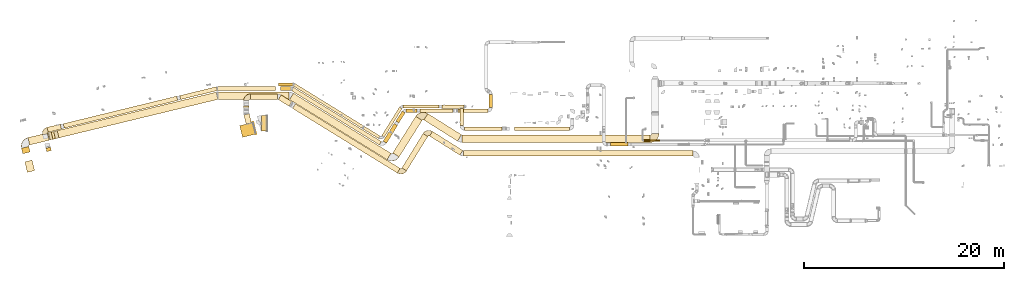
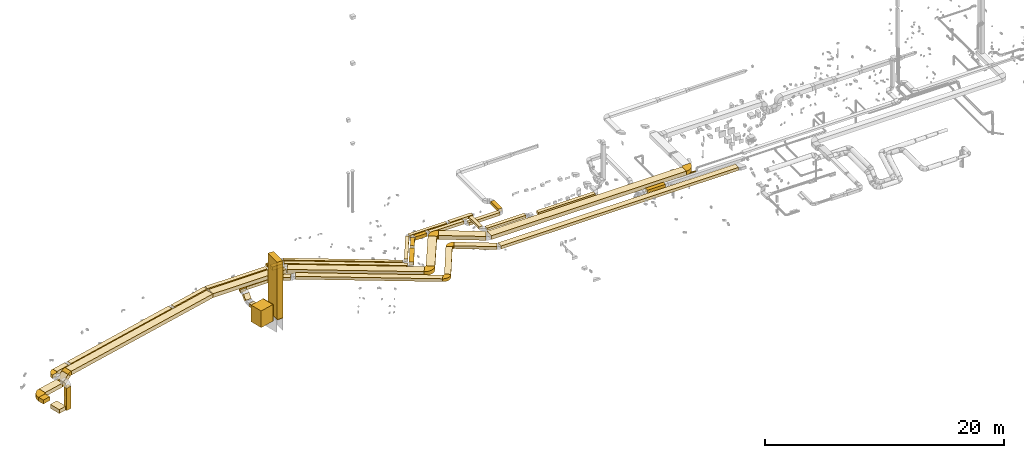
# One storey, part 1 of 97: 55 coverings.
"""IFC2X3 building model written with IfcOpenShell, lengths in millimetres."""

from ifc_helpers import new_model, entity, si_unit, converted_unit, derived_unit, direction, frame, frame_2d, origin, origin_2d_with_axis, place, context, subcontext, project, spatial, polyline, circle_curve, parameter, trimmed, segment, composite_curve, rectangle, circle, outline, extrude, element, save


model = new_model("IFC2X3")

# Units and contexts
model_context = context("Model", 3, precision=0.01, world=origin(), true_north=direction((6.12303176911189e-17, 1.0)))
body_context = subcontext(model_context, "Body", "Model", "MODEL_VIEW")
ifc_project = project(units=[si_unit("LENGTHUNIT", "METRE", prefix="MILLI"), si_unit("AREAUNIT", "SQUARE_METRE"), si_unit("VOLUMEUNIT", "CUBIC_METRE"), converted_unit("PLANEANGLEUNIT", "DEGREE", entity("IfcRatioMeasure", 0.0174532925199433), si_unit("PLANEANGLEUNIT", "RADIAN"), dimensions=[0, 0, 0, 0, 0, 0, 0]), si_unit("MASSUNIT", "GRAM", prefix="KILO"), derived_unit("MASSDENSITYUNIT", [(si_unit("MASSUNIT", "GRAM", prefix="KILO"), 1), (si_unit("LENGTHUNIT", "METRE"), -3)]), derived_unit("MOMENTOFINERTIAUNIT", [(si_unit("LENGTHUNIT", "METRE"), 4)]), si_unit("TIMEUNIT", "SECOND"), si_unit("FREQUENCYUNIT", "HERTZ"), si_unit("THERMODYNAMICTEMPERATUREUNIT", "DEGREE_CELSIUS"), derived_unit("THERMALTRANSMITTANCEUNIT", [(si_unit("MASSUNIT", "GRAM", prefix="KILO"), 1), (si_unit("THERMODYNAMICTEMPERATUREUNIT", "KELVIN"), -1), (si_unit("TIMEUNIT", "SECOND"), -3)]), derived_unit("VOLUMETRICFLOWRATEUNIT", [(si_unit("LENGTHUNIT", "METRE"), 3), (si_unit("TIMEUNIT", "SECOND"), -1)]), derived_unit("MASSFLOWRATEUNIT", [(si_unit("MASSUNIT", "GRAM", prefix="KILO"), 1), (si_unit("TIMEUNIT", "SECOND"), -1)]), derived_unit("ROTATIONALFREQUENCYUNIT", [(si_unit("TIMEUNIT", "SECOND"), -1)]), si_unit("ELECTRICCURRENTUNIT", "AMPERE"), si_unit("ELECTRICVOLTAGEUNIT", "VOLT"), si_unit("POWERUNIT", "WATT"), si_unit("FORCEUNIT", "NEWTON", prefix="KILO"), si_unit("ILLUMINANCEUNIT", "LUX"), si_unit("LUMINOUSFLUXUNIT", "LUMEN"), si_unit("LUMINOUSINTENSITYUNIT", "CANDELA"), derived_unit("USERDEFINED", [(si_unit("MASSUNIT", "GRAM", prefix="KILO"), -1), (si_unit("LENGTHUNIT", "METRE"), -2), (si_unit("TIMEUNIT", "SECOND"), 3), (si_unit("LUMINOUSFLUXUNIT", "LUMEN"), 1)]), derived_unit("LINEARVELOCITYUNIT", [(si_unit("LENGTHUNIT", "METRE"), 1), (si_unit("TIMEUNIT", "SECOND"), -1)]), si_unit("PRESSUREUNIT", "PASCAL"), derived_unit("USERDEFINED", [(si_unit("LENGTHUNIT", "METRE"), -2), (si_unit("MASSUNIT", "GRAM", prefix="KILO"), 1), (si_unit("TIMEUNIT", "SECOND"), -2)]), derived_unit("LINEARFORCEUNIT", [(si_unit("MASSUNIT", "GRAM", prefix="KILO"), 1), (si_unit("LENGTHUNIT", "METRE"), 1), (si_unit("TIMEUNIT", "SECOND"), -2), (si_unit("LENGTHUNIT", "METRE"), -1)]), derived_unit("PLANARFORCEUNIT", [(si_unit("MASSUNIT", "GRAM", prefix="KILO"), 1), (si_unit("LENGTHUNIT", "METRE"), 1), (si_unit("TIMEUNIT", "SECOND"), -2), (si_unit("LENGTHUNIT", "METRE"), -2)])], contexts=[model_context])

# Site, building, storey
site_placement = place(None, origin())
site = spatial("IfcSite", under=ifc_project, at=site_placement, CompositionType="ELEMENT")
building_placement = place(site_placement, origin())
building = spatial("IfcBuilding", under=site, at=building_placement, CompositionType="ELEMENT")
storey_placement = place(building_placement, frame((0.0, 0.0, -4900.0)))
storey = spatial("IfcBuildingStorey", under=building, at=storey_placement, CompositionType="ELEMENT", Elevation=-4900.0)

# Coverings
covering_1_placement = place(storey_placement, frame((-3208.67, 9959.38, 2456.63)))
element("IfcCovering", 1, at=covering_1_placement, inside=storey, PredefinedType="INSULATION", context=body_context, shape_type="SweptSolid", body=[
    extrude(rectangle(XDim=1360.0, YDim=1200.0, at=origin_2d_with_axis()), frame((803.51, 744.9, 0.0), z_axis=(0.0, 0.0, 1.0), x_axis=(-0.971126038182249, -0.238567009379859, 0.0)), (0.0, 0.0, 1.0), 1700.0),
])
covering_2_placement = place(storey_placement, frame((-1887.94, 10283.83, 2456.63)))
element("IfcCovering", 2, at=covering_2_placement, inside=storey, PredefinedType="INSULATION", context=body_context, shape_type="SweptSolid", body=[
    extrude(rectangle(XDim=50.0000000000032, YDim=1200.0, at=origin_2d_with_axis()), frame((167.42, 588.64, 0.0), z_axis=(0.0, 0.0, 1.0), x_axis=(-0.971126038182248, -0.238567009379862, 0.0)), (0.0, 0.0, 1.0), 1700.0),
])
covering_3_placement = place(storey_placement, frame((-2794.72, 11277.28, 3200.0)))
element("IfcCovering", 3, at=covering_3_placement, inside=storey, PredefinedType="INSULATION", context=body_context, shape_type="SweptSolid", body=[
    extrude(rectangle(XDim=955.574923264787, YDim=550.0, at=origin_2d_with_axis()), frame((381.04, 529.6, 0.0), z_axis=(0.0, 0.0, 1.0), x_axis=(-0.238567009379864, 0.971126038182248, 0.0)), (0.0, 0.0, 1.0), 300.0),
])
covering_4_placement = place(storey_placement, frame((-2814.21, 12716.67, 3324.48)))
element("IfcCovering", 4, at=covering_4_placement, inside=storey, PredefinedType="INSULATION", context=body_context, shape_type="SweptSolid", body=[
    extrude(rectangle(XDim=549.999806950779, YDim=299.999999999998, at=origin_2d_with_axis()), frame((0.0, 300.52, 300.52), z_axis=(1.0, 0.0, 0.0), x_axis=(0.0, 0.707106781186531, 0.707106781186564)), (0.0, 0.0, 1.0), 550.0),
])
covering_5_placement = place(storey_placement, frame((-2139.22, 13746.58, 3750.0)))
element("IfcCovering", 5, at=covering_5_placement, inside=storey, PredefinedType="INSULATION", context=body_context, shape_type="SweptSolid", body=[
    extrude(rectangle(XDim=2716.99429169592, YDim=550.000000000001, at=origin_2d_with_axis()), frame((1358.5, 275.0, 0.01), z_axis=(-6.17522343880966e-06, 0.0, 1.0), x_axis=(-1.0, 0.0, -6.17522343880966e-06)), (0.0, 0.0, 1.0), 300.0),
])
covering_6_placement = place(storey_placement, frame((643.41, 13064.74, 3750.02)))
element("IfcCovering", 6, at=covering_6_placement, inside=storey, PredefinedType="INSULATION", context=body_context, shape_type="SweptSolid", body=[
    extrude(rectangle(XDim=1263.23389062577, YDim=550.0, at=origin_2d_with_axis()), frame((681.94, 565.66, 0.0), z_axis=(-2.60900913908676e-07, 1.60945190401383e-07, 1.0), x_axis=(0.851088816343154, -0.525021739259923, 3.0654957379145e-07)), (0.0, 0.0, 1.0), 300.0),
])
covering_7_placement = place(storey_placement, frame((15756.5, 8178.55, 3900.0)))
element("IfcCovering", 7, at=covering_7_placement, inside=storey, PredefinedType="INSULATION", context=body_context, shape_type="SweptSolid", body=[
    extrude(rectangle(XDim=3583.77962437014, YDim=550.0, at=origin_2d_with_axis()), frame((1663.15, 1186.95, 0.0), z_axis=(0.0, 0.0, 1.0), x_axis=(-0.846428930081417, 0.532501705463211, 0.0)), (0.0, 0.0, 1.0), 300.0),
])
covering_8_placement = place(storey_placement, frame((19149.36, 8074.88, 3900.0)))
element("IfcCovering", 8, at=covering_8_placement, inside=storey, PredefinedType="INSULATION", context=body_context, shape_type="SweptSolid", body=[
    extrude(rectangle(XDim=22913.242395076, YDim=550.000000000001, at=origin_2d_with_axis()), frame((11456.62, 275.0, 0.0)), (0.0, 0.0, 1.0), 300.0),
])
covering_9_placement = place(storey_placement, frame((18780.54, 11120.0, 4175.0)))
element("IfcCovering", 9, at=covering_9_placement, inside=storey, PredefinedType="INSULATION", context=body_context, shape_type="SweptSolid", body=[
    extrude(rectangle(XDim=1744.07623364408, YDim=349.999999999998, at=origin_2d_with_axis()), frame((175.0, 872.04, 0.0), z_axis=(0.0, -1.06842108780278e-08, 1.0), x_axis=(0.0, -1.0, -1.06842108780278e-08)), (0.0, 0.0, 1.0), 250.0),
])
covering_10_placement = place(storey_placement, frame((24231.5, 10645.0, 4025.0)))
element("IfcCovering", 10, at=covering_10_placement, inside=storey, PredefinedType="INSULATION", context=body_context, shape_type="SweptSolid", body=[
    extrude(rectangle(XDim=5495.94816144537, YDim=349.999999999998, at=origin_2d_with_axis()), frame((2747.97, 175.0, 0.0), z_axis=(0.0, 0.0, 1.0), x_axis=(-1.0, 0.0, 0.0)), (0.0, 0.0, 1.0), 250.0),
])
covering_11_placement = place(storey_placement, frame((2157.8, 9839.85, 4225.0)))
element("IfcCovering", 11, at=covering_11_placement, inside=storey, PredefinedType="INSULATION", context=body_context, shape_type="SweptSolid", body=[
    extrude(rectangle(XDim=9982.84701585936, YDim=299.999999999999, at=origin_2d_with_axis()), frame((4326.9, 2748.27, 0.0), z_axis=(0.0, 0.0, 1.0), x_axis=(-0.851088806352979, 0.525021755454629, 0.0)), (0.0, 0.0, 1.0), 250.0),
])
covering_12_placement = place(storey_placement, frame((10983.34, 9976.93, 4225.0)))
element("IfcCovering", 12, at=covering_12_placement, inside=storey, PredefinedType="INSULATION", context=body_context, shape_type="SweptSolid", body=[
    extrude(rectangle(XDim=3355.15981218457, YDim=300.0, at=origin_2d_with_axis()), frame((1014.01, 1503.39, 0.0), z_axis=(0.0, 0.0, 1.0), x_axis=(0.528543816030324, 0.84890602220511, 0.0)), (0.0, 0.0, 1.0), 250.0),
])
covering_13_placement = place(storey_placement, frame((13117.47, 12884.08, 4225.0)))
element("IfcCovering", 13, at=covering_13_placement, inside=storey, PredefinedType="INSULATION", context=body_context, shape_type="SweptSolid", body=[
    extrude(rectangle(XDim=3578.96571761756, YDim=300.000000000001, at=origin_2d_with_axis()), frame((1789.48, 150.0, 0.0)), (0.0, 0.0, 1.0), 250.0),
])
covering_14_placement = place(storey_placement, frame((16996.44, 12859.08, 4225.0)))
element("IfcCovering", 14, at=covering_14_placement, inside=storey, PredefinedType="INSULATION", context=body_context, shape_type="SweptSolid", body=[
    extrude(rectangle(XDim=2209.11071214288, YDim=349.999999999998, at=origin_2d_with_axis()), frame((1104.56, 175.0, 0.0)), (0.0, 0.0, 1.0), 250.0),
])
covering_15_placement = place(storey_placement, frame((-24682.89, 6452.66, 3350.0)))
element("IfcCovering", 15, at=covering_15_placement, inside=storey, PredefinedType="INSULATION", context=body_context, shape_type="SweptSolid", body=[
    extrude(rectangle(XDim=1079.40182496234, YDim=749.999999999998, at=origin_2d_with_axis()), frame((493.23, 613.74, 0.0), z_axis=(0.0, 0.0, 1.0), x_axis=(-0.239234929345687, 0.970961713241549, 0.0)), (0.0, 0.0, 1.0), 400.0),
])
covering_16_placement = place(storey_placement, frame((-25019.06, 8317.78, 3350.0)))
element("IfcCovering", 16, at=covering_16_placement, inside=storey, PredefinedType="INSULATION", context=body_context, shape_type="SweptSolid", body=[
    extrude(rectangle(XDim=563.648083324207, YDim=749.999999999999, at=origin_2d_with_axis()), frame((431.53, 363.36, 0.0), z_axis=(0.0, 0.0, 1.0), x_axis=(-0.239240175396018, 0.970960420653943, 0.0)), (0.0, 0.0, 1.0), 400.0),
])
covering_17_placement = place(storey_placement, frame((-24375.2, 9195.88, 3350.0)))
element("IfcCovering", 17, at=covering_17_placement, inside=storey, PredefinedType="INSULATION", context=body_context, shape_type="SweptSolid", body=[
    extrude(rectangle(XDim=2019.81232553969, YDim=750.0, at=origin_2d_with_axis()), frame((1069.77, 601.95, 0.0), z_axis=(0.0, 0.0, 1.0), x_axis=(0.971963923974013, 0.235130028905367, 0.0)), (0.0, 0.0, 1.0), 400.0),
])
covering_18_placement = place(storey_placement, frame((-5356.59, 13750.46, 4075.0)))
element("IfcCovering", 18, at=covering_18_placement, inside=storey, PredefinedType="INSULATION", context=body_context, shape_type="SweptSolid", body=[
    extrude(rectangle(XDim=7058.84355228445, YDim=749.999999999998, at=origin_2d_with_axis()), frame((3529.42, 375.0, 0.0), z_axis=(0.0, 0.0, 1.0), x_axis=(-1.0, 0.0, 0.0)), (0.0, 0.0, 1.0), 400.0),
])
covering_19_placement = place(storey_placement, frame((1767.89, 7718.09, 4075.0)))
element("IfcCovering", 19, at=covering_19_placement, inside=storey, PredefinedType="INSULATION", context=body_context, shape_type="SweptSolid", body=[
    extrude(rectangle(XDim=11454.2887651558, YDim=750.0, at=origin_2d_with_axis()), frame((5071.19, 3326.03, 0.0), z_axis=(0.0, 0.0, 1.0), x_axis=(-0.851088797264639, 0.525021770187323, 0.0)), (0.0, 0.0, 1.0), 400.0),
])
covering_20_placement = place(storey_placement, frame((15190.71, 9579.38, 4075.0)))
element("IfcCovering", 20, at=covering_20_placement, inside=storey, PredefinedType="INSULATION", context=body_context, shape_type="SweptSolid", body=[
    extrude(rectangle(XDim=3972.83667806784, YDim=750.000000000002, at=origin_2d_with_axis()), frame((1881.05, 1375.18, 0.0), z_axis=(0.0, 0.0, 1.0), x_axis=(-0.84642893008142, 0.532501705463206, 0.0)), (0.0, 0.0, 1.0), 400.0),
])
covering_21_placement = place(storey_placement, frame((19019.38, 9445.01, 4075.0)))
element("IfcCovering", 21, at=covering_21_placement, inside=storey, PredefinedType="INSULATION", context=body_context, shape_type="SweptSolid", body=[
    extrude(rectangle(XDim=18790.1284833971, YDim=750.0, at=origin_2d_with_axis()), frame((9395.06, 375.0, 0.0)), (0.0, 0.0, 1.0), 400.0),
])
covering_22_placement = place(storey_placement, frame((12081.7, 7996.85, 4075.0)))
element("IfcCovering", 22, at=covering_22_placement, inside=storey, PredefinedType="INSULATION", context=body_context, shape_type="SweptSolid", body=[
    extrude(rectangle(XDim=4322.66331644128, YDim=749.999999999999, at=origin_2d_with_axis()), frame((1468.32, 2029.1, 0.0), z_axis=(0.0, 0.0, 1.0), x_axis=(0.532501705463199, 0.846428930081424, 0.0)), (0.0, 0.0, 1.0), 400.0),
])
covering_23_placement = place(storey_placement, frame((-22596.61, 8522.08, 1715.0)))
element("IfcCovering", 23, at=covering_23_placement, inside=storey, PredefinedType="INSULATION", context=body_context, shape_type="SweptSolid", body=[
    extrude(rectangle(XDim=350.0, YDim=499.999999999999, at=origin_2d_with_axis()), frame((284.28, 229.14, 0.0), z_axis=(1.3083476965024e-06, -5.37909916616792e-06, 1.0), x_axis=(0.236337623155927, -0.971670997740676, -5.53592643867416e-06)), (0.0, 0.0, 1.0), 2284.95162721462),
])
covering_24_placement = place(storey_placement, frame((-20841.09, 10877.98, 4125.0)))
element("IfcCovering", 24, at=covering_24_placement, inside=storey, PredefinedType="INSULATION", context=body_context, shape_type="SweptSolid", body=[
    extrude(rectangle(XDim=11666.6777760886, YDim=449.999999999998, at=origin_2d_with_axis()), frame((5720.72, 1599.9, 0.0), z_axis=(0.0, 0.0, 1.0), x_axis=(0.971559912665503, 0.236793868377963, 0.0)), (0.0, 0.0, 1.0), 350.0),
])
covering_25_placement = place(storey_placement, frame((-9208.82, 13735.91, 4125.0)))
element("IfcCovering", 25, at=covering_25_placement, inside=storey, PredefinedType="INSULATION", context=body_context, shape_type="SweptSolid", body=[
    extrude(rectangle(XDim=3774.44741521228, YDim=400.000000000001, at=origin_2d_with_axis()), frame((1880.91, 641.19, 0.0), z_axis=(0.0, 0.0, 1.0), x_axis=(0.9715599126655, 0.236793868377977, 0.0)), (0.0, 0.0, 1.0), 350.0),
])
covering_26_placement = place(storey_placement, frame((866.6, 14633.23, 4125.0)))
element("IfcCovering", 26, at=covering_26_placement, inside=storey, PredefinedType="INSULATION", context=body_context, shape_type="SweptSolid", body=[
    extrude(rectangle(XDim=1032.75527236275, YDim=400.0, at=origin_2d_with_axis()), frame((516.38, 200.0, 0.0), z_axis=(0.0, 0.0, 1.0), x_axis=(-1.0, 0.0, 0.0)), (0.0, 0.0, 1.0), 350.0),
])
covering_27_placement = place(storey_placement, frame((1964.98, 9200.43, 4125.0)))
element("IfcCovering", 27, at=covering_27_placement, inside=storey, PredefinedType="INSULATION", context=body_context, shape_type="SweptSolid", body=[
    extrude(rectangle(XDim=10312.3007437821, YDim=399.999999999999, at=origin_2d_with_axis()), frame((4493.35, 2877.31, 0.0), z_axis=(0.0, 0.0, 1.0), x_axis=(-0.85108880635298, 0.525021755454628, 0.0)), (0.0, 0.0, 1.0), 350.0),
])
covering_28_placement = place(storey_placement, frame((11123.37, 9369.8, 4125.0)))
element("IfcCovering", 28, at=covering_28_placement, inside=storey, PredefinedType="INSULATION", context=body_context, shape_type="SweptSolid", body=[
    extrude(rectangle(XDim=2073.56434596333, YDim=400.000000000001, at=origin_2d_with_axis()), frame((717.77, 985.84, 0.0), z_axis=(0.0, 0.0, 1.0), x_axis=(0.52854381603038, 0.848906022205075, 0.0)), (0.0, 0.0, 1.0), 350.0),
])
covering_29_placement = place(storey_placement, frame((12399.12, 11397.94, 4125.0)))
element("IfcCovering", 29, at=covering_29_placement, inside=storey, PredefinedType="INSULATION", context=body_context, shape_type="SweptSolid", body=[
    extrude(rectangle(XDim=1180.32053409491, YDim=350.0, at=origin_2d_with_axis()), frame((460.48, 593.49, 0.0), z_axis=(0.0, 0.0, 1.0), x_axis=(0.528543816030324, 0.84890602220511, 0.0)), (0.0, 0.0, 1.0), 350.0),
])
covering_30_placement = place(storey_placement, frame((13426.2, 12458.83, 4125.0)))
element("IfcCovering", 30, at=covering_30_placement, inside=storey, PredefinedType="INSULATION", context=body_context, shape_type="SweptSolid", body=[
    extrude(rectangle(XDim=1097.78533008796, YDim=350.000000000002, at=origin_2d_with_axis()), frame((548.9, 175.02, 0.0)), (0.0, 0.0, 1.0), 350.0),
])
covering_31_placement = place(storey_placement, frame((14823.99, 12458.83, 4150.0)))
element("IfcCovering", 31, at=covering_31_placement, inside=storey, PredefinedType="INSULATION", context=body_context, shape_type="SweptSolid", body=[
    extrude(rectangle(XDim=3262.38838163226, YDim=349.999999999998, at=origin_2d_with_axis()), frame((1631.19, 175.0, 0.0), z_axis=(0.0, 0.0, 1.0), x_axis=(-1.0, 0.0, 0.0)), (0.0, 0.0, 1.0), 300.0),
])
covering_32_placement = place(storey_placement, frame((18591.56, 12458.83, 3825.0)))
element("IfcCovering", 32, at=covering_32_placement, inside=storey, PredefinedType="INSULATION", context=body_context, shape_type="SweptSolid", body=[
    extrude(rectangle(XDim=2988.13225493354, YDim=349.999999999998, at=origin_2d_with_axis()), frame((1494.07, 175.0, 0.0)), (0.0, 0.0, 1.0), 300.0),
])
covering_33_placement = place(storey_placement, frame((21704.69, 12933.83, 3825.0)))
element("IfcCovering", 33, at=covering_33_placement, inside=storey, PredefinedType="INSULATION", context=body_context, shape_type="SweptSolid", body=[
    extrude(rectangle(XDim=1318.57318, YDim=349.999999999998, at=origin_2d_with_axis()), frame((175.0, 659.29, 0.0), z_axis=(0.0, 0.0, 1.0), x_axis=(0.0, 1.0, 0.0)), (0.0, 0.0, 1.0), 300.0),
])
covering_34_placement = place(storey_placement, frame((-22461.73, 10467.62, 4125.0)))
element("IfcCovering", 34, at=covering_34_placement, inside=storey, PredefinedType="INSULATION", context=body_context, shape_type="SweptSolid", body=[
    extrude(rectangle(XDim=1360.43438674366, YDim=499.999999999998, at=origin_2d_with_axis()), frame((719.99, 403.38, 0.0), z_axis=(0.0, 0.0, 1.0), x_axis=(-0.971787577071847, -0.235857806843081, 0.0)), (0.0, 0.0, 1.0), 350.0),
])
covering_35_placement = place(storey_placement, frame((33827.72, 9070.01, 3850.0)))
element("IfcCovering", 35, at=covering_35_placement, inside=storey, PredefinedType="INSULATION", context=body_context, shape_type="SweptSolid", body=[
    extrude(rectangle(XDim=1760.00000000005, YDim=350.000000000001, at=origin_2d_with_axis()), frame((880.0, 175.0, 0.0), z_axis=(0.0, 0.0, 1.0), x_axis=(-1.0, 0.0, 0.0)), (0.0, 0.0, 1.0), 300.0),
])
covering_36_placement = place(storey_placement, frame((-1010.64, 10573.4, 2234.0)))
element("IfcCovering", 36, at=covering_36_placement, inside=storey, PredefinedType="INSULATION", context=body_context, shape_type="SweptSolid", body=[
    extrude(rectangle(XDim=550.0, YDim=1550.0, at=origin_2d_with_axis()), frame((275.0, 775.0, 0.0), z_axis=(0.0, 0.0, 1.0), x_axis=(-1.0, 0.0, 0.0)), (0.0, 0.0, 1.0), 5846.000025),
])
covering_37_placement = place(storey_placement, frame((-1010.64, 10573.4, 2182.9)))
element("IfcCovering", 37, at=covering_37_placement, inside=storey, PredefinedType="INSULATION", context=body_context, shape_type="SweptSolid", body=[
    extrude(rectangle(XDim=550.0, YDim=1550.0, at=origin_2d_with_axis()), frame((275.0, 775.0, 0.0), z_axis=(0.0, 0.0, 1.0), x_axis=(-1.0, 0.0, 0.0)), (0.0, 0.0, 1.0), 51.0960000000021),
])
covering_38_placement = place(storey_placement, frame((655.1, 15099.67, 4225.0)))
element("IfcCovering", 38, at=covering_38_placement, inside=storey, PredefinedType="INSULATION", context=body_context, shape_type="SweptSolid", body=[
    extrude(rectangle(XDim=1437.07091939898, YDim=300.000000000001, at=origin_2d_with_axis()), frame((718.54, 150.0, 0.0)), (0.0, 0.0, 1.0), 250.0),
])
covering_39_placement = place(storey_placement, frame((-21445.65, 9904.58, 4075.0)))
element("IfcCovering", 39, at=covering_39_placement, inside=storey, PredefinedType="INSULATION", context=body_context, shape_type="SweptSolid", body=[
    extrude(rectangle(XDim=16341.481014958, YDim=749.999999999999, at=origin_2d_with_axis()), frame((8029.84, 2285.67, 0.0), z_axis=(0.0, 0.0, 1.0), x_axis=(0.971963923974013, 0.235130028905368, 0.0)), (0.0, 0.0, 1.0), 400.0),
])
covering_40_placement = place(storey_placement, frame((-22326.11, 9691.59, 3503.77)))
element("IfcCovering", 40, at=covering_40_placement, inside=storey, PredefinedType="INSULATION", context=body_context, shape_type="SweptSolid", body=[
    extrude(rectangle(XDim=400.000000000002, YDim=750.000000000001, at=frame_2d((0.0, 0.0), x_axis=(0.0, 1.0))), frame((225.63, 397.74, 141.42), z_axis=(0.687282281710701, 0.166262037899579, 0.707106781186556), x_axis=(0.235130028905379, -0.97196392397401, 0.0)), (0.0, 0.0, 1.0), 756.066017177977),
])
covering_41_placement = place(storey_placement, frame((-5417.41, 14633.23, 4125.0)))
element("IfcCovering", 41, at=covering_41_placement, inside=storey, PredefinedType="INSULATION", context=body_context, shape_type="SweptSolid", body=[
    extrude(rectangle(XDim=5802.50714283817, YDim=400.0, at=origin_2d_with_axis()), frame((2901.25, 200.0, 0.0), z_axis=(0.0, 0.0, 1.0), x_axis=(-1.0, 0.0, 0.0)), (0.0, 0.0, 1.0), 350.0),
])
covering_42_placement = place(storey_placement, frame((12996.54, 6611.87, 3900.0)))
element("IfcCovering", 42, at=covering_42_placement, inside=storey, PredefinedType="INSULATION", context=body_context, shape_type="SweptSolid", body=[
    extrude(rectangle(XDim=4035.85371403088, YDim=550.0, at=origin_2d_with_axis()), frame((1293.5, 1861.82, 0.0), z_axis=(-1.3415460443922e-08, -2.17471906588074e-08, 1.0), x_axis=(0.525021755454614, 0.851088806352989, 2.55521991318351e-08)), (0.0, 0.0, 1.0), 300.0),
])
covering_43_placement = place(storey_placement, frame((19255.54, 10645.0, 4175.0)))
element("IfcCovering", 43, at=covering_43_placement, inside=storey, PredefinedType="INSULATION", context=body_context, shape_type="SweptSolid", body=[
    extrude(rectangle(XDim=3767.66742285411, YDim=349.999999999998, at=origin_2d_with_axis()), frame((1883.83, 175.0, 0.0)), (0.0, 0.0, 1.0), 250.0),
])
covering_44_placement = place(storey_placement, frame((2065.05, 6391.77, 3900.0)))
element("IfcCovering", 44, at=covering_44_placement, inside=storey, PredefinedType="INSULATION", context=body_context, shape_type="SweptSolid", body=[
    extrude(rectangle(XDim=12302.7306166602, YDim=549.999999999999, at=origin_2d_with_axis()), frame((5379.74, 3463.65, 0.0), z_axis=(0.0, 0.0, 1.0), x_axis=(-0.851088806352981, 0.525021755454627, 0.0)), (0.0, 0.0, 1.0), 300.0),
])
covering_45_placement = place(storey_placement, frame((37158.02, 9554.05, 3890.9)))
element("IfcCovering", 45, at=covering_45_placement, inside=storey, PredefinedType="INSULATION", context=body_context, shape_type="SweptSolid", body=[
    extrude(circle(Radius=87.5, at=origin_2d_with_axis()), frame((0.0, 89.1, 89.1), z_axis=(1.0, 0.0, 0.0), x_axis=(0.0, -1.0, 0.0)), (0.0, 0.0, 1.0), 1656.78869999999),
])
covering_46_placement = place(storey_placement, frame((-2815.81, 13619.98, 3750.0)))
element("IfcCovering", 46, at=covering_46_placement, inside=storey, PredefinedType="INSULATION", context=body_context, shape_type="SweptSolid", body=[
    extrude(outline(composite_curve([segment(polyline([(-200.0, 75.0), (-200.0, -475.0)]), True, "CONTINUOUS"), segment(trimmed(circle_curve(frame_2d((-200.0, 200.0), x_axis=(1.0, 0.0)), 675.0), [parameter(270.0)], [parameter(0.0)], True, "PARAMETER"), True, "CONTINUOUS"), segment(polyline([(475.0, 200.0), (-75.0, 200.0)]), True, "CONTINUOUS"), segment(trimmed(circle_curve(frame_2d((-200.0, 200.0), x_axis=(1.0, 0.0)), 125.0), [parameter(270.0)], [parameter(360.0)], True, "PARAMETER"), False, "CONTINUOUS")], self_intersect=False)), frame((476.6, 201.6, 0.0), z_axis=(0.0, 0.0, -1.0), x_axis=(0.0, 1.0, 0.0)), (0.0, 0.0, -1.0), 300.0),
])
covering_47_placement = place(storey_placement, frame((37807.91, 9443.41, 4075.0)))
element("IfcCovering", 47, at=covering_47_placement, inside=storey, PredefinedType="INSULATION", context=body_context, shape_type="SweptSolid", body=[
    extrude(outline(composite_curve([segment(polyline([(-250.0, 125.0), (-250.0, -625.0)]), True, "CONTINUOUS"), segment(trimmed(circle_curve(frame_2d((-250.0, 250.0), x_axis=(1.0, 0.0)), 875.0), [parameter(270.0)], [parameter(0.0)], True, "PARAMETER"), True, "CONTINUOUS"), segment(polyline([(625.0, 250.0), (-125.0, 250.0)]), True, "CONTINUOUS"), segment(trimmed(circle_curve(frame_2d((-250.0, 250.0), x_axis=(1.0, 0.0)), 125.0), [parameter(270.0)], [parameter(360.0)], True, "PARAMETER"), False, "CONTINUOUS")], self_intersect=False)), frame((251.6, 626.6, 0.0), z_axis=(0.0, 0.0, -1.0), x_axis=(0.0, -1.0, 0.0)), (0.0, 0.0, -1.0), 400.0),
])
covering_48_placement = place(storey_placement, frame((14381.93, 11654.09, 4075.0)))
element("IfcCovering", 48, at=covering_48_placement, inside=storey, PredefinedType="INSULATION", context=body_context, shape_type="SweptSolid", body=[
    extrude(outline(composite_curve([segment(polyline([(-250.0, 125.0), (-250.0, -625.0)]), True, "CONTINUOUS"), segment(trimmed(circle_curve(frame_2d((-250.0, 250.0), x_axis=(1.0, 0.0)), 875.0), [parameter(270.0)], [parameter(0.0)], True, "PARAMETER"), True, "CONTINUOUS"), segment(polyline([(625.0, 250.0), (-125.0, 250.0)]), True, "CONTINUOUS"), segment(trimmed(circle_curve(frame_2d((-250.0, 250.0), x_axis=(1.0, 0.0)), 125.0), [parameter(270.0)], [parameter(360.0)], True, "PARAMETER"), False, "CONTINUOUS")], self_intersect=False)), frame((663.74, 279.77, 0.0), z_axis=(0.0, 0.0, -1.0), x_axis=(0.532501705463203, 0.846428930081422, 0.0)), (0.0, 0.0, -1.0), 400.0),
])
covering_49_placement = place(storey_placement, frame((11514.91, 7587.21, 4075.0)))
element("IfcCovering", 49, at=covering_49_placement, inside=storey, PredefinedType="INSULATION", context=body_context, shape_type="SweptSolid", body=[
    extrude(outline(composite_curve([segment(polyline([(-251.1, 125.0), (-244.49, -624.98)]), True, "CONTINUOUS"), segment(trimmed(circle_curve(frame_2d((-252.2, 249.99), x_axis=(1.0, 0.0)), 875.0), [parameter(270.504932557271)], [parameter(0.0)], True, "PARAMETER"), True, "CONTINUOUS"), segment(polyline([(622.8, 249.99), (-127.2, 249.99)]), True, "CONTINUOUS"), segment(trimmed(circle_curve(frame_2d((-252.2, 249.99), x_axis=(1.0, 0.0)), 125.0), [parameter(270.504932557271)], [parameter(360.0)], True, "PARAMETER"), False, "CONTINUOUS")], self_intersect=False)), frame((541.34, 529.69, 0.0), z_axis=(0.0, 0.0, -1.0), x_axis=(-0.525021769576294, -0.851088797641572, 0.0)), (0.0, 0.0, -1.0), 400.0),
])
covering_50_placement = place(storey_placement, frame((-21808.07, 9815.7, 4036.79)))
element("IfcCovering", 50, at=covering_50_placement, inside=storey, PredefinedType="INSULATION", context=body_context, shape_type="SweptSolid", body=[
    extrude(outline(composite_curve([segment(polyline([(-152.4, -114.9), (247.6, -114.9)]), True, "CONTINUOUS"), segment(trimmed(circle_curve(frame_2d((-277.4, -114.9), x_axis=(0.707106781186553, 0.707106781186553)), 525.0), [parameter(315.0)], [parameter(0.0)], True, "PARAMETER"), True, "CONTINUOUS"), segment(polyline([(93.83, 256.33), (-189.02, -26.52)]), True, "CONTINUOUS"), segment(trimmed(circle_curve(frame_2d((-277.4, -114.9), x_axis=(0.707106781186553, 0.707106781186553)), 125.0), [parameter(314.999999999999)], [parameter(360.0)], True, "PARAMETER"), False, "CONTINUOUS")], self_intersect=False)), frame((427.08, 61.87, 190.61), z_axis=(-0.235130028905371, 0.971963923974012, 0.0), x_axis=(-0.687282281710709, -0.166262037899574, 0.707106781186549)), (0.0, 0.0, 1.0), 750.000000000001),
])
covering_51_placement = place(storey_placement, frame((-25045.94, 8863.46, 3350.0)))
element("IfcCovering", 51, at=covering_51_placement, inside=storey, PredefinedType="INSULATION", context=body_context, shape_type="SweptSolid", body=[
    extrude(outline(composite_curve([segment(polyline([(-249.47, 125.0), (-252.64, -624.99)]), True, "CONTINUOUS"), segment(trimmed(circle_curve(frame_2d((-248.94, 250.0), x_axis=(1.0, 0.0)), 875.0), [parameter(269.75789796984)], [parameter(0.0)], True, "PARAMETER"), True, "CONTINUOUS"), segment(polyline([(626.06, 250.0), (-123.94, 250.0)]), True, "CONTINUOUS"), segment(trimmed(circle_curve(frame_2d((-248.94, 250.0), x_axis=(1.0, 0.0)), 125.0), [parameter(269.75789796984)], [parameter(360.0)], True, "PARAMETER"), False, "CONTINUOUS")], self_intersect=False)), frame((574.95, 394.11, 0.0), z_axis=(0.0, 0.0, -1.0), x_axis=(-0.235130028905366, 0.971963923974013, 0.0)), (0.0, 0.0, -1.0), 400.0),
])
covering_52_placement = place(storey_placement, frame((-22413.61, 9669.21, 3348.4)))
element("IfcCovering", 52, at=covering_52_placement, inside=storey, PredefinedType="INSULATION", context=body_context, shape_type="SweptSolid", body=[
    extrude(outline(composite_curve([segment(polyline([(-189.02, 26.52), (93.83, -256.33)]), True, "CONTINUOUS"), segment(trimmed(circle_curve(frame_2d((-277.4, 114.9), x_axis=(1.0, 0.0)), 525.0), [parameter(315.0)], [parameter(0.0)], True, "PARAMETER"), True, "CONTINUOUS"), segment(polyline([(247.6, 114.9), (-152.4, 114.9)]), True, "CONTINUOUS"), segment(trimmed(circle_curve(frame_2d((-277.4, 114.9), x_axis=(1.0, 0.0)), 125.0), [parameter(315.0)], [parameter(360.0)], True, "PARAMETER"), False, "CONTINUOUS")], self_intersect=False)), frame((289.63, 28.61, 249.19), z_axis=(0.23513002890536, -0.971963923974015, 0.0), x_axis=(0.687282281710725, 0.16626203789956, -0.707106781186537)), (0.0, 0.0, -1.0), 750.000000000002),
])
covering_53_placement = place(storey_placement, frame((-22940.22, 10196.85, 4124.99)))
element("IfcCovering", 53, at=covering_53_placement, inside=storey, PredefinedType="INSULATION", context=body_context, shape_type="SweptSolid", body=[
    extrude(outline(composite_curve([segment(polyline([(-187.47, 62.5), (-187.71, -437.5)]), True, "CONTINUOUS"), segment(trimmed(circle_curve(frame_2d((-187.41, 187.5), x_axis=(1.0, 0.0)), 625.0), [parameter(269.972841931102)], [parameter(0.0)], True, "PARAMETER"), True, "CONTINUOUS"), segment(polyline([(437.59, 187.5), (-62.41, 187.5)]), True, "CONTINUOUS"), segment(trimmed(circle_curve(frame_2d((-187.41, 187.5), x_axis=(1.0, 0.0)), 125.0), [parameter(269.972841931102)], [parameter(360.0)], True, "PARAMETER"), False, "CONTINUOUS")], self_intersect=False)), frame((399.49, 287.2, 0.0), z_axis=(-3.39368023648227e-06, 1.3982731114607e-05, -1.0), x_axis=(-0.235857806818667, 0.971787576971251, 1.43886703684145e-05)), (0.0, 0.0, -1.0), 350.0),
])
covering_54_placement = place(storey_placement, frame((12534.17, 6289.95, 3900.0)))
element("IfcCovering", 54, at=covering_54_placement, inside=storey, PredefinedType="INSULATION", context=body_context, shape_type="SweptSolid", body=[
    extrude(outline(composite_curve([segment(polyline([(-200.0, 75.0), (-200.0, -475.0)]), True, "CONTINUOUS"), segment(trimmed(circle_curve(frame_2d((-200.0, 200.0), x_axis=(1.0, 0.0)), 675.0), [parameter(270.0)], [parameter(0.0)], True, "PARAMETER"), True, "CONTINUOUS"), segment(polyline([(475.0, 200.0), (-75.0, 200.0)]), True, "CONTINUOUS"), segment(trimmed(circle_curve(frame_2d((-200.0, 200.0), x_axis=(1.0, 0.0)), 125.0), [parameter(270.0)], [parameter(360.0)], True, "PARAMETER"), False, "CONTINUOUS")], self_intersect=False)), frame((421.2, 401.09, 0.0), z_axis=(0.0, 0.0, -1.0), x_axis=(-0.525021755454627, -0.851088806352981, 0.0)), (0.0, 0.0, -1.0), 300.0),
])
covering_55_placement = place(storey_placement, frame((15113.86, 10045.14, 3900.0)))
element("IfcCovering", 55, at=covering_55_placement, inside=storey, PredefinedType="INSULATION", context=body_context, shape_type="SweptSolid", body=[
    extrude(outline(composite_curve([segment(polyline([(-199.34, 75.0), (-204.19, -474.98)]), True, "CONTINUOUS"), segment(trimmed(circle_curve(frame_2d((-198.24, 199.99), x_axis=(1.0, 0.0)), 675.0), [parameter(269.495066492049)], [parameter(0.0)], True, "PARAMETER"), True, "CONTINUOUS"), segment(polyline([(476.76, 199.99), (-73.24, 199.99)]), True, "CONTINUOUS"), segment(trimmed(circle_curve(frame_2d((-198.24, 199.99), x_axis=(1.0, 0.0)), 125.0), [parameter(269.495066492048)], [parameter(360.0)], True, "PARAMETER"), False, "CONTINUOUS")], self_intersect=False)), frame((512.36, 210.26, 0.0), z_axis=(0.0, 0.0, -1.0), x_axis=(0.53250170546321, 0.846428930081417, 0.0)), (0.0, 0.0, -1.0), 300.0),
])

save(model, "model.ifc")
